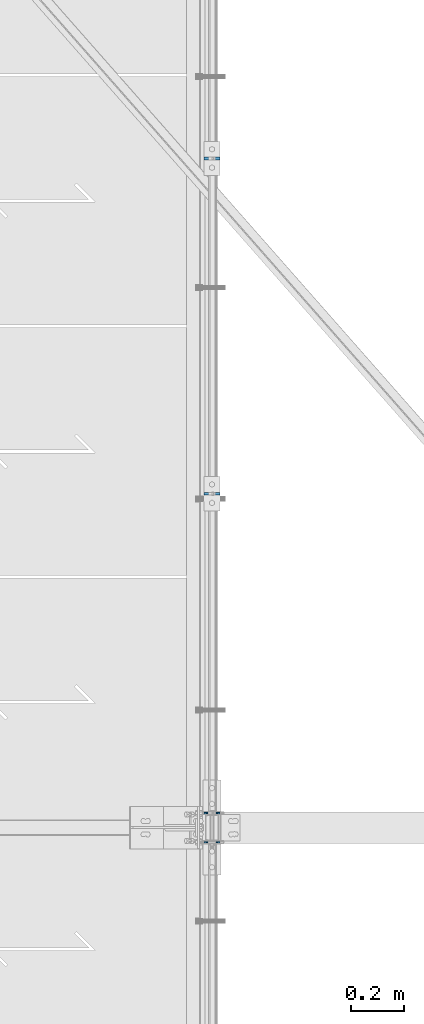
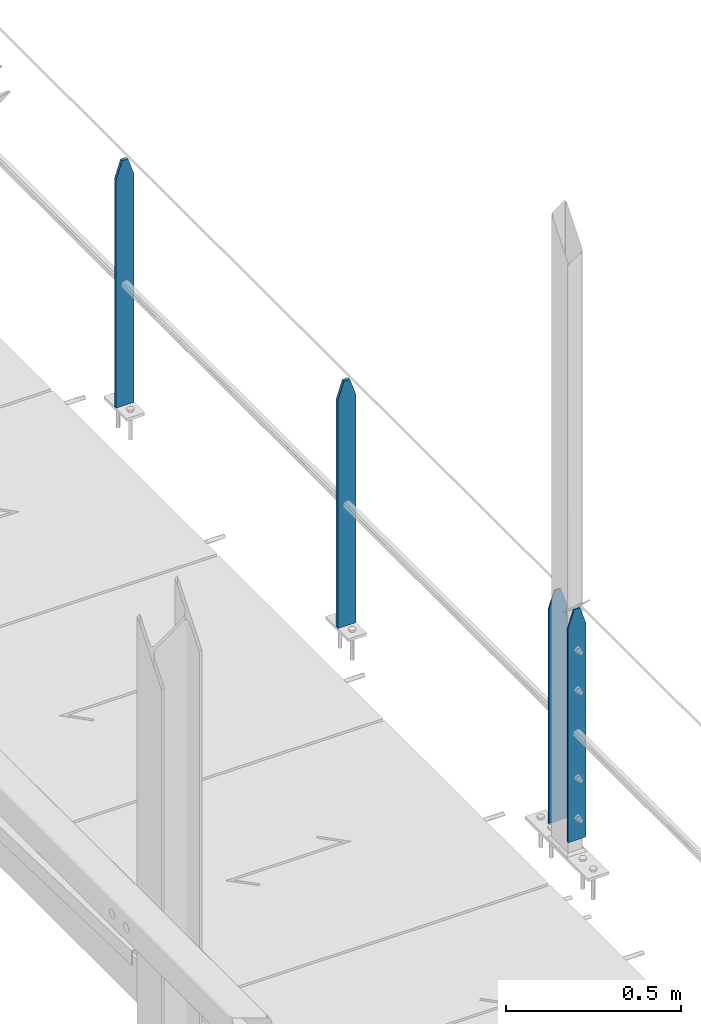
# One storey, part 22 of 496: 4 columns, 2 elements without a shape of their own.
"""IFC2X3 building model written with IfcOpenShell, lengths in millimetres."""

from ifc_helpers import new_model, si_unit, frame, origin_with_axes, origin_2d_with_axis, place, context, subcontext, project, spatial, rectangle, extrude, clip, halfspace, material, type_object, element, aggregate, save


model = new_model("IFC2X3")

# Units and contexts
model_context = context("Model", 3, precision=1e-05, world=origin_with_axes())
body_context = subcontext(model_context, "Body", "Model", "MODEL_VIEW")
ifc_project = project(units=[si_unit("LENGTHUNIT", "METRE", prefix="MILLI"), si_unit("AREAUNIT", "SQUARE_METRE"), si_unit("VOLUMEUNIT", "CUBIC_METRE"), si_unit("MASSUNIT", "GRAM", prefix="KILO"), si_unit("TIMEUNIT", "SECOND"), si_unit("PLANEANGLEUNIT", "RADIAN"), si_unit("SOLIDANGLEUNIT", "STERADIAN"), si_unit("THERMODYNAMICTEMPERATUREUNIT", "DEGREE_CELSIUS"), si_unit("LUMINOUSINTENSITYUNIT", "LUMEN")], contexts=[model_context])

# Site, building, storey
site_placement = place(None, origin_with_axes())
site = spatial("IfcSite", under=ifc_project, at=site_placement, CompositionType="ELEMENT")
building_placement = place(site_placement, origin_with_axes())
building = spatial("IfcBuilding", under=site, at=building_placement, Name="Undefined", CompositionType="ELEMENT")
storey_placement = place(building_placement, origin_with_axes())
storey = spatial("IfcBuildingStorey", under=building, at=storey_placement, Name="Undefined", CompositionType="ELEMENT", Elevation=0.0)

# Assembly, columns
assembly_1_placement = place(storey_placement, origin_with_axes())
assembly_1 = element("IfcElementAssembly", 1, at=assembly_1_placement, inside=storey, Name="MAIN COURANTE", AssemblyPlace="NOTDEFINED", PredefinedType="NOTDEFINED")
ifc_material = material(Name="Undefined/S235-E24")
column_type_1 = type_object("IfcColumnType", PredefinedType="NOTDEFINED")
column_1_placement = place(assembly_1_placement, frame((13993.9998862411, 5065.00344717076, 8250.00000552562), z_axis=(0.0, 0.0, 1.0), x_axis=(1.0, 0.0, 0.0)))
column_1 = element("IfcColumn", 2, at=column_1_placement, type_object=column_type_1, material=ifc_material, Name="MONTANT", context=body_context, shape_type="Clipping", body=[
    clip(clip(extrude(rectangle(XDim=10.0, YDim=60.0, at=origin_2d_with_axis()), frame((0.0, 0.0, 857.599997130677), z_axis=(0.0, 0.0, -1.0), x_axis=(0.0, 1.0, 0.0)), (0.0, 0.0, 1.0), 857.6), halfspace(frame((30.0000001657245, -5.000000004674, 797.599997170884), z_axis=(0.948683298050514, 0.0, 0.316227766016838), x_axis=(-0.316227766016838, 0.0, 0.948683298050514)), False)), halfspace(frame((-29.9999998342682, 4.99999999524351, 797.599997177174), z_axis=(-0.948683298050514, 0.0, 0.316227766016838), x_axis=(0.316227766016838, 0.0, 0.948683298050514)), False)),
])
column_2_placement = place(assembly_1_placement, frame((13993.9998872962, 6335.00344717076, 8250.00000465505), z_axis=(0.0, 0.0, 1.0), x_axis=(1.0, 0.0, 0.0)))
column_2 = element("IfcColumn", 3, at=column_2_placement, type_object=column_type_1, material=ifc_material, Name="MONTANT", context=body_context, shape_type="Clipping", body=[
    clip(clip(extrude(rectangle(XDim=10.0, YDim=60.0, at=origin_2d_with_axis()), frame((0.0, 0.0, 857.599997130677), z_axis=(0.0, 0.0, -1.0), x_axis=(0.0, 1.0, 0.0)), (0.0, 0.0, 1.0), 857.6), halfspace(frame((30.0000001657245, -5.000000004674, 797.599997170884), z_axis=(0.948683298050514, 0.0, 0.316227766016838), x_axis=(-0.316227766016838, 0.0, 0.948683298050514)), False)), halfspace(frame((-29.9999998342682, 4.99999999524351, 797.599997177174), z_axis=(-0.948683298050514, 0.0, 0.316227766016838), x_axis=(0.316227766016838, 0.0, 0.948683298050514)), False)),
])

# Assembly, column
assembly_2_placement = place(storey_placement, origin_with_axes())
assembly_2 = element("IfcElementAssembly", 4, at=assembly_2_placement, inside=storey, Name="MAIN COURANTE", AssemblyPlace="NOTDEFINED", PredefinedType="NOTDEFINED")
column_type_2 = type_object("IfcColumnType", PredefinedType="NOTDEFINED")
column_3_placement = place(assembly_2_placement, frame((13993.9998855045, 3745.00000892015, 8300.00000650458), z_axis=(0.0, 0.0, 1.0), x_axis=(1.0, 0.0, 0.0)))
column_3 = element("IfcColumn", 5, at=column_3_placement, type_object=column_type_2, material=ifc_material, Name="MONTANT", context=body_context, shape_type="Clipping", body=[
    clip(clip(extrude(rectangle(XDim=5.0, YDim=60.0, at=origin_2d_with_axis()), frame((0.0, 0.0, 807.599997128624), z_axis=(0.0, 0.0, -1.0), x_axis=(0.0, 1.0, 0.0)), (0.0, 0.0, 1.0), 807.6), halfspace(frame((29.9999999717475, -5.00000000468981, 747.599997131425), z_axis=(0.948683298050514, 0.0, 0.316227766016838), x_axis=(-0.316227766016838, 0.0, 0.948683298050514)), False)), halfspace(frame((-30.000000028238, 4.99999999522788, 747.599997137713), z_axis=(-0.948683298050514, 0.0, 0.316227766016838), x_axis=(0.316227766016838, 0.0, 0.948683298050514)), False)),
])
aggregate(assembly_2, [column_3])

# Column
column_4_placement = place(assembly_1_placement, frame((13993.9998855875, 3855.00000891184, 8300.00000642738), z_axis=(0.0, 0.0, 1.0), x_axis=(1.0, 0.0, 0.0)))
column_4 = element("IfcColumn", 6, at=column_4_placement, type_object=column_type_2, material=ifc_material, Name="MONTANT", context=body_context, shape_type="Clipping", body=[
    clip(clip(extrude(rectangle(XDim=5.0, YDim=60.0, at=origin_2d_with_axis()), frame((0.0, 0.0, 807.599997128624), z_axis=(0.0, 0.0, -1.0), x_axis=(0.0, 1.0, 0.0)), (0.0, 0.0, 1.0), 807.6), halfspace(frame((29.9999999717475, -5.00000000468981, 747.599997131425), z_axis=(0.948683298050514, 0.0, 0.316227766016838), x_axis=(-0.316227766016838, 0.0, 0.948683298050514)), False)), halfspace(frame((-30.000000028238, 4.99999999522788, 747.599997137713), z_axis=(-0.948683298050514, 0.0, 0.316227766016838), x_axis=(0.316227766016838, 0.0, 0.948683298050514)), False)),
])

aggregate(assembly_1, [column_4, column_1, column_2])

save(model, "model.ifc")
